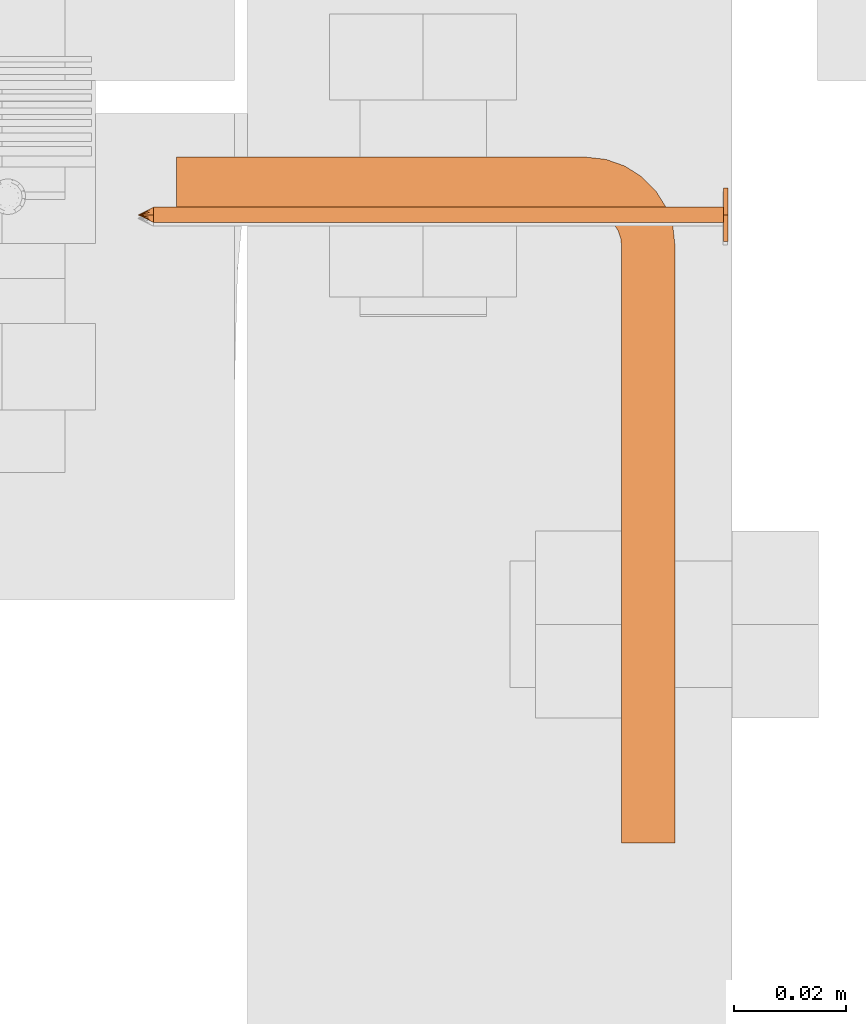
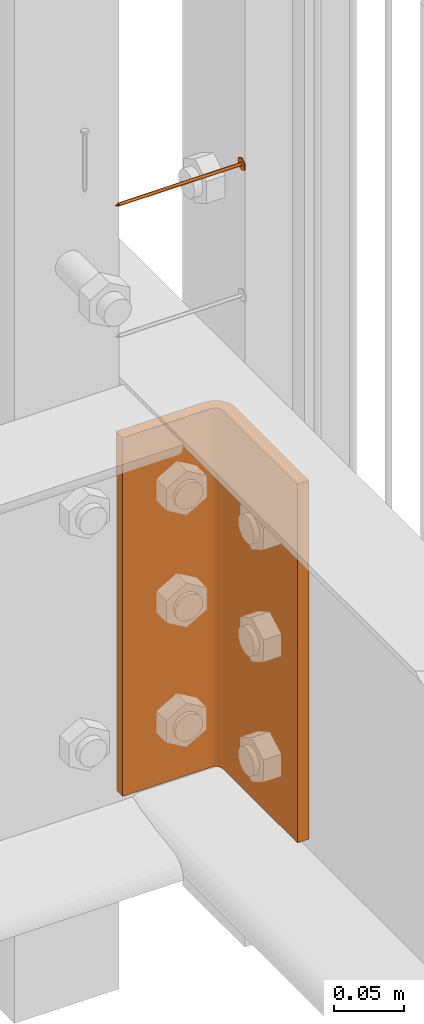
# One storey, part 26 of 44: 2 proxies.
"""IFC4 building model written with IfcOpenShell, lengths in feet."""

from ifc_helpers import new_model, entity, si_unit, converted_unit, derived_unit, direction, frame, frame_2d, origin, place, context, subcontext, project, spatial, polyline, circle_curve, parameter, trimmed, segment, composite_curve, outline, extrude, source, transform, mapped, material, type_object, type_shapes, element, save


model = new_model("IFC4")

# Units and contexts
model_context = context("Model", 3, precision=0.0001, world=origin(), true_north=direction((6.12303176911189e-17, 1.0)))
body_context = subcontext(model_context, "Body", "Model", "MODEL_VIEW")
ifc_project = project(units=[converted_unit("LENGTHUNIT", "FOOT", entity("IfcRatioMeasure", 0.3048), si_unit("LENGTHUNIT", "METRE"), dimensions=[1, 0, 0, 0, 0, 0, 0]), converted_unit("AREAUNIT", "SQUARE FOOT", entity("IfcRatioMeasure", 0.09290304), si_unit("AREAUNIT", "SQUARE_METRE"), dimensions=[2, 0, 0, 0, 0, 0, 0]), converted_unit("VOLUMEUNIT", "CUBIC FOOT", entity("IfcRatioMeasure", 0.028316846592), si_unit("VOLUMEUNIT", "CUBIC_METRE"), dimensions=[3, 0, 0, 0, 0, 0, 0]), converted_unit("PLANEANGLEUNIT", "DEGREE", entity("IfcRatioMeasure", 0.0174532925199433), si_unit("PLANEANGLEUNIT", "RADIAN"), dimensions=[0, 0, 0, 0, 0, 0, 0]), si_unit("MASSUNIT", "GRAM", prefix="KILO"), derived_unit("MASSDENSITYUNIT", [(si_unit("MASSUNIT", "GRAM", prefix="KILO"), 1), (si_unit("LENGTHUNIT", "METRE"), -3)]), derived_unit("MOMENTOFINERTIAUNIT", [(si_unit("LENGTHUNIT", "METRE"), 4)]), si_unit("TIMEUNIT", "SECOND"), si_unit("FREQUENCYUNIT", "HERTZ"), si_unit("THERMODYNAMICTEMPERATUREUNIT", "DEGREE_CELSIUS"), derived_unit("THERMALTRANSMITTANCEUNIT", [(si_unit("MASSUNIT", "GRAM", prefix="KILO"), 1), (si_unit("THERMODYNAMICTEMPERATUREUNIT", "KELVIN"), -1), (si_unit("TIMEUNIT", "SECOND"), -3)]), derived_unit("VOLUMETRICFLOWRATEUNIT", [(si_unit("LENGTHUNIT", "METRE"), 3), (si_unit("TIMEUNIT", "SECOND"), -1)]), si_unit("ELECTRICCURRENTUNIT", "AMPERE"), si_unit("ELECTRICVOLTAGEUNIT", "VOLT"), si_unit("POWERUNIT", "WATT"), si_unit("FORCEUNIT", "NEWTON"), si_unit("ILLUMINANCEUNIT", "LUX"), si_unit("LUMINOUSFLUXUNIT", "LUMEN"), si_unit("LUMINOUSINTENSITYUNIT", "CANDELA"), derived_unit("USERDEFINED", [(si_unit("MASSUNIT", "GRAM", prefix="KILO"), -1), (si_unit("LENGTHUNIT", "METRE"), -2), (si_unit("TIMEUNIT", "SECOND"), 3), (si_unit("LUMINOUSFLUXUNIT", "LUMEN"), 1)]), derived_unit("LINEARVELOCITYUNIT", [(si_unit("LENGTHUNIT", "METRE"), 1), (si_unit("TIMEUNIT", "SECOND"), -1)]), si_unit("PRESSUREUNIT", "PASCAL"), derived_unit("USERDEFINED", [(si_unit("LENGTHUNIT", "METRE"), -2), (si_unit("MASSUNIT", "GRAM", prefix="KILO"), 1), (si_unit("TIMEUNIT", "SECOND"), -2)]), derived_unit("LINEARFORCEUNIT", [(si_unit("MASSUNIT", "GRAM", prefix="KILO"), 1), (si_unit("LENGTHUNIT", "METRE"), 1), (si_unit("TIMEUNIT", "SECOND"), -2), (si_unit("LENGTHUNIT", "METRE"), -1)]), derived_unit("PLANARFORCEUNIT", [(si_unit("MASSUNIT", "GRAM", prefix="KILO"), 1), (si_unit("LENGTHUNIT", "METRE"), 1), (si_unit("TIMEUNIT", "SECOND"), -2), (si_unit("LENGTHUNIT", "METRE"), -2)])], contexts=[model_context])

# Site, building, storey
site_placement = place(None, origin())
site = spatial("IfcSite", under=ifc_project, at=site_placement, CompositionType="ELEMENT")
building_placement = place(site_placement, origin())
building = spatial("IfcBuilding", under=site, at=building_placement, CompositionType="ELEMENT")
storey_placement = place(building_placement, origin())
storey = spatial("IfcBuildingStorey", under=building, at=storey_placement, CompositionType="ELEMENT", Elevation=0.0)

# Proxies
ifc_material_1 = material(Category="Materials")
building_element_proxy_type_1 = type_object("IfcBuildingElementProxyType", PredefinedType="NOTDEFINED", material=ifc_material_1)
cartesian_point_1 = entity("IfcCartesianPoint", [0.0, -0.00455729166677942, -0.333333333333231])
vertex_point_1 = entity("IfcVertexPoint", cartesian_point_1)
cartesian_point_2 = entity("IfcCartesianPoint", [0.0, 0.00455729166667798, -0.333333333333232])
vertex_point_2 = entity("IfcVertexPoint", cartesian_point_2)
cartesian_point_3 = entity("IfcCartesianPoint", [0.0, 0.0, -0.333333333333232])
ifc_direction_1 = entity("IfcDirection", [0.0, 0.0, 1.0])
ifc_direction_2 = entity("IfcDirection", [0.0, 1.0, 0.0])
edge_curve_1 = entity("IfcEdgeCurve", vertex_point_1, vertex_point_2, entity("IfcTrimmedCurve", entity("IfcCircle", entity("IfcAxis2Placement3D", cartesian_point_3, ifc_direction_1, ifc_direction_2), 0.0045572916667287), [cartesian_point_1], [cartesian_point_2], True, "CARTESIAN"), True)
vertex_point_3 = entity("IfcVertexPoint", cartesian_point_3)
ifc_direction_3 = entity("IfcDirection", [0.0, -1.0, 0.0])
edge_curve_2 = entity("IfcEdgeCurve", vertex_point_2, vertex_point_3, entity("IfcTrimmedCurve", entity("IfcLine", cartesian_point_2, entity("IfcVector", ifc_direction_3, 1.0)), [cartesian_point_2], [cartesian_point_3], True, "CARTESIAN"), True)
edge_curve_3 = entity("IfcEdgeCurve", vertex_point_3, vertex_point_1, entity("IfcTrimmedCurve", entity("IfcLine", cartesian_point_3, entity("IfcVector", ifc_direction_3, 1.0)), [cartesian_point_3], [cartesian_point_1], True, "CARTESIAN"), True)
edge_curve_4 = entity("IfcEdgeCurve", vertex_point_2, vertex_point_1, entity("IfcTrimmedCurve", entity("IfcCircle", entity("IfcAxis2Placement3D", cartesian_point_3, ifc_direction_1, ifc_direction_2), 0.0045572916667287), [cartesian_point_2], [cartesian_point_1], True, "CARTESIAN"), True)
cartesian_point_4 = entity("IfcCartesianPoint", [0.0, 0.0, -0.342447916666333])
vertex_point_4 = entity("IfcVertexPoint", cartesian_point_4)
edge_curve_5 = entity("IfcEdgeCurve", vertex_point_4, vertex_point_2, entity("IfcTrimmedCurve", entity("IfcLine", cartesian_point_4, entity("IfcVector", entity("IfcDirection", [0.0, 0.447213595514596, 0.894427190992597]), 1.0)), [cartesian_point_4], [cartesian_point_2], True, "CARTESIAN"), True)
edge_curve_6 = entity("IfcEdgeCurve", vertex_point_1, vertex_point_4, entity("IfcTrimmedCurve", entity("IfcLine", cartesian_point_1, entity("IfcVector", entity("IfcDirection", [0.0, 0.447213595514579, -0.894427190992605]), 1.0)), [cartesian_point_1], [cartesian_point_4], True, "CARTESIAN"), True)
cartesian_point_5 = entity("IfcCartesianPoint", [-0.00455729166669724, 0.0, -0.333333333333231])
cartesian_point_6 = entity("IfcCartesianPoint", [0.0, 0.0, -0.338202184590857])
ifc_direction_4 = entity("IfcDirection", [0.0, 0.0, -1.0])
cartesian_point_7 = entity("IfcCartesianPoint", [-0.0156249999999625, 0.00902109795594613, 0.00260416666704037])
vertex_point_5 = entity("IfcVertexPoint", cartesian_point_7)
cartesian_point_8 = entity("IfcCartesianPoint", [-0.0156249999999625, -0.0090210979562493, 0.00260416666704046])
vertex_point_6 = entity("IfcVertexPoint", cartesian_point_8)
ifc_direction_5 = entity("IfcDirection", [0.0, -1.0, 0.0])
edge_curve_7 = entity("IfcEdgeCurve", vertex_point_5, vertex_point_6, entity("IfcTrimmedCurve", entity("IfcLine", cartesian_point_7, entity("IfcVector", ifc_direction_5, 1.0)), [cartesian_point_7], [cartesian_point_8], True, "CARTESIAN"), True)
cartesian_point_9 = entity("IfcCartesianPoint", [0.0, -0.0180421959123274, 0.0026041666670405])
vertex_point_7 = entity("IfcVertexPoint", cartesian_point_9)
edge_curve_8 = entity("IfcEdgeCurve", vertex_point_6, vertex_point_7, entity("IfcTrimmedCurve", entity("IfcLine", cartesian_point_8, entity("IfcVector", entity("IfcDirection", [0.866025403784438, -0.500000000000001, 0.0]), 1.0)), [cartesian_point_8], [cartesian_point_9], True, "CARTESIAN"), True)
cartesian_point_10 = entity("IfcCartesianPoint", [0.0156250000000786, -0.00902109795620598, 0.00260416666704046])
vertex_point_8 = entity("IfcVertexPoint", cartesian_point_10)
edge_curve_9 = entity("IfcEdgeCurve", vertex_point_7, vertex_point_8, entity("IfcTrimmedCurve", entity("IfcLine", cartesian_point_9, entity("IfcVector", entity("IfcDirection", [0.86602540378444, 0.499999999999998, 0.0]), 1.0)), [cartesian_point_9], [cartesian_point_10], True, "CARTESIAN"), True)
cartesian_point_11 = entity("IfcCartesianPoint", [0.0156250000000786, 0.00902109795590273, 0.00260416666704037])
vertex_point_9 = entity("IfcVertexPoint", cartesian_point_11)
ifc_direction_6 = entity("IfcDirection", [0.0, 1.0, 0.0])
edge_curve_10 = entity("IfcEdgeCurve", vertex_point_8, vertex_point_9, entity("IfcTrimmedCurve", entity("IfcLine", cartesian_point_10, entity("IfcVector", ifc_direction_6, 1.0)), [cartesian_point_10], [cartesian_point_11], True, "CARTESIAN"), True)
cartesian_point_12 = entity("IfcCartesianPoint", [0.0, 0.0180421959120243, 0.00260416666704032])
vertex_point_10 = entity("IfcVertexPoint", cartesian_point_12)
edge_curve_11 = entity("IfcEdgeCurve", vertex_point_9, vertex_point_10, entity("IfcTrimmedCurve", entity("IfcLine", cartesian_point_11, entity("IfcVector", entity("IfcDirection", [-0.866025403784437, 0.500000000000003, 0.0]), 1.0)), [cartesian_point_11], [cartesian_point_12], True, "CARTESIAN"), True)
edge_curve_12 = entity("IfcEdgeCurve", vertex_point_10, vertex_point_5, entity("IfcTrimmedCurve", entity("IfcLine", cartesian_point_12, entity("IfcVector", entity("IfcDirection", [-0.866025403784438, -0.500000000000001, 0.0]), 1.0)), [cartesian_point_12], [cartesian_point_7], True, "CARTESIAN"), True)
ifc_direction_7 = entity("IfcDirection", [0.0, 0.0, 1.0])
cartesian_point_13 = entity("IfcCartesianPoint", [-0.0156249999999625, 0.00902109795594612, 0.0])
vertex_point_11 = entity("IfcVertexPoint", cartesian_point_13)
cartesian_point_14 = entity("IfcCartesianPoint", [0.0, 0.0180421959120242, 0.0])
vertex_point_12 = entity("IfcVertexPoint", cartesian_point_14)
edge_curve_13 = entity("IfcEdgeCurve", vertex_point_11, vertex_point_12, entity("IfcTrimmedCurve", entity("IfcLine", cartesian_point_13, entity("IfcVector", entity("IfcDirection", [0.866025403784438, 0.500000000000001, 0.0]), 1.0)), [cartesian_point_13], [cartesian_point_14], True, "CARTESIAN"), True)
cartesian_point_15 = entity("IfcCartesianPoint", [0.0156250000000786, 0.00902109795590272, 0.0])
vertex_point_13 = entity("IfcVertexPoint", cartesian_point_15)
edge_curve_14 = entity("IfcEdgeCurve", vertex_point_12, vertex_point_13, entity("IfcTrimmedCurve", entity("IfcLine", cartesian_point_14, entity("IfcVector", entity("IfcDirection", [0.866025403784437, -0.500000000000003, 0.0]), 1.0)), [cartesian_point_14], [cartesian_point_15], True, "CARTESIAN"), True)
cartesian_point_16 = entity("IfcCartesianPoint", [0.0156250000000786, -0.00902109795620599, 0.0])
vertex_point_14 = entity("IfcVertexPoint", cartesian_point_16)
edge_curve_15 = entity("IfcEdgeCurve", vertex_point_13, vertex_point_14, entity("IfcTrimmedCurve", entity("IfcLine", cartesian_point_15, entity("IfcVector", ifc_direction_5, 1.0)), [cartesian_point_15], [cartesian_point_16], True, "CARTESIAN"), True)
cartesian_point_17 = entity("IfcCartesianPoint", [0.0, -0.0180421959123274, 0.0])
vertex_point_15 = entity("IfcVertexPoint", cartesian_point_17)
edge_curve_16 = entity("IfcEdgeCurve", vertex_point_14, vertex_point_15, entity("IfcTrimmedCurve", entity("IfcLine", cartesian_point_16, entity("IfcVector", entity("IfcDirection", [-0.86602540378444, -0.499999999999998, 0.0]), 1.0)), [cartesian_point_16], [cartesian_point_17], True, "CARTESIAN"), True)
cartesian_point_18 = entity("IfcCartesianPoint", [-0.0156249999999625, -0.00902109795624931, 0.0])
vertex_point_16 = entity("IfcVertexPoint", cartesian_point_18)
edge_curve_17 = entity("IfcEdgeCurve", vertex_point_15, vertex_point_16, entity("IfcTrimmedCurve", entity("IfcLine", cartesian_point_17, entity("IfcVector", entity("IfcDirection", [-0.866025403784438, 0.500000000000001, 0.0]), 1.0)), [cartesian_point_17], [cartesian_point_18], True, "CARTESIAN"), True)
edge_curve_18 = entity("IfcEdgeCurve", vertex_point_16, vertex_point_11, entity("IfcTrimmedCurve", entity("IfcLine", cartesian_point_18, entity("IfcVector", ifc_direction_6, 1.0)), [cartesian_point_18], [cartesian_point_13], True, "CARTESIAN"), True)
ifc_direction_8 = entity("IfcDirection", [0.0, 0.0, -1.0])
edge_curve_19 = entity("IfcEdgeCurve", vertex_point_5, vertex_point_11, entity("IfcTrimmedCurve", entity("IfcLine", cartesian_point_7, entity("IfcVector", ifc_direction_8, 1.0)), [cartesian_point_7], [cartesian_point_13], True, "CARTESIAN"), True)
edge_curve_20 = entity("IfcEdgeCurve", vertex_point_16, vertex_point_6, entity("IfcTrimmedCurve", entity("IfcLine", cartesian_point_8, entity("IfcVector", ifc_direction_7, 1.0)), [cartesian_point_18], [cartesian_point_8], True, "CARTESIAN"), True)
edge_curve_21 = entity("IfcEdgeCurve", vertex_point_15, vertex_point_7, entity("IfcTrimmedCurve", entity("IfcLine", cartesian_point_9, entity("IfcVector", ifc_direction_7, 1.0)), [cartesian_point_17], [cartesian_point_9], True, "CARTESIAN"), True)
edge_curve_22 = entity("IfcEdgeCurve", vertex_point_14, vertex_point_8, entity("IfcTrimmedCurve", entity("IfcLine", cartesian_point_10, entity("IfcVector", ifc_direction_7, 1.0)), [cartesian_point_16], [cartesian_point_10], True, "CARTESIAN"), True)
edge_curve_23 = entity("IfcEdgeCurve", vertex_point_13, vertex_point_9, entity("IfcTrimmedCurve", entity("IfcLine", cartesian_point_11, entity("IfcVector", ifc_direction_7, 1.0)), [cartesian_point_15], [cartesian_point_11], True, "CARTESIAN"), True)
edge_curve_24 = entity("IfcEdgeCurve", vertex_point_12, vertex_point_10, entity("IfcTrimmedCurve", entity("IfcLine", cartesian_point_12, entity("IfcVector", ifc_direction_7, 1.0)), [cartesian_point_14], [cartesian_point_12], True, "CARTESIAN"), True)
cartesian_point_19 = entity("IfcCartesianPoint", [0.0, -0.00455729166682102, 0.0])
vertex_point_17 = entity("IfcVertexPoint", cartesian_point_19)
cartesian_point_20 = entity("IfcCartesianPoint", [0.0, 0.00455729166651231, 0.0])
vertex_point_18 = entity("IfcVertexPoint", cartesian_point_20)
cartesian_point_21 = entity("IfcCartesianPoint", [0.0, 0.0, 0.0])
ifc_direction_9 = entity("IfcDirection", [0.0, 0.0, 1.0])
ifc_direction_10 = entity("IfcDirection", [0.0, 1.0, 0.0])
edge_curve_25 = entity("IfcEdgeCurve", vertex_point_17, vertex_point_18, entity("IfcTrimmedCurve", entity("IfcCircle", entity("IfcAxis2Placement3D", cartesian_point_21, ifc_direction_9, ifc_direction_10), 0.00455729166666667), [cartesian_point_19], [cartesian_point_20], True, "CARTESIAN"), True)
edge_curve_26 = entity("IfcEdgeCurve", vertex_point_18, vertex_point_17, entity("IfcTrimmedCurve", entity("IfcCircle", entity("IfcAxis2Placement3D", cartesian_point_21, ifc_direction_9, ifc_direction_10), 0.00455729166666667), [cartesian_point_20], [cartesian_point_19], True, "CARTESIAN"), True)
cartesian_point_22 = entity("IfcCartesianPoint", [0.0, -0.00455729166682389, -0.333333333333339])
vertex_point_19 = entity("IfcVertexPoint", cartesian_point_22)
cartesian_point_23 = entity("IfcCartesianPoint", [0.0, 0.00455729166650944, -0.333333333333339])
vertex_point_20 = entity("IfcVertexPoint", cartesian_point_23)
cartesian_point_24 = entity("IfcCartesianPoint", [0.0, 0.0, -0.333333333333339])
ifc_direction_11 = entity("IfcDirection", [0.0, 0.0, -1.0])
edge_curve_27 = entity("IfcEdgeCurve", vertex_point_19, vertex_point_20, entity("IfcTrimmedCurve", entity("IfcCircle", entity("IfcAxis2Placement3D", cartesian_point_24, ifc_direction_11, ifc_direction_10), 0.00455729166666667), [cartesian_point_22], [cartesian_point_23], True, "CARTESIAN"), True)
edge_curve_28 = entity("IfcEdgeCurve", vertex_point_20, vertex_point_19, entity("IfcTrimmedCurve", entity("IfcCircle", entity("IfcAxis2Placement3D", cartesian_point_24, ifc_direction_11, ifc_direction_10), 0.00455729166666667), [cartesian_point_23], [cartesian_point_22], True, "CARTESIAN"), True)
edge_curve_29 = entity("IfcEdgeCurve", vertex_point_17, vertex_point_19, entity("IfcTrimmedCurve", entity("IfcLine", cartesian_point_19, entity("IfcVector", ifc_direction_11, 1.0)), [cartesian_point_19], [cartesian_point_22], True, "CARTESIAN"), True)
edge_curve_30 = entity("IfcEdgeCurve", vertex_point_20, vertex_point_18, entity("IfcTrimmedCurve", entity("IfcLine", cartesian_point_20, entity("IfcVector", ifc_direction_9, 1.0)), [cartesian_point_23], [cartesian_point_20], True, "CARTESIAN"), True)
shared_shape_1 = source(origin(), body_context, "Body", "AdvancedBrep", [
    entity("IfcAdvancedBrep", entity("IfcClosedShell", [entity("IfcAdvancedFace", [entity("IfcFaceOuterBound", entity("IfcEdgeLoop", [entity("IfcOrientedEdge", None, None, edge_curve_1, True), entity("IfcOrientedEdge", None, None, edge_curve_2, True), entity("IfcOrientedEdge", None, None, edge_curve_3, True)]), True)], entity("IfcPlane", entity("IfcAxis2Placement3D", cartesian_point_3, ifc_direction_1, ifc_direction_2)), True), entity("IfcAdvancedFace", [entity("IfcFaceOuterBound", entity("IfcEdgeLoop", [entity("IfcOrientedEdge", None, None, edge_curve_4, True), entity("IfcOrientedEdge", None, None, edge_curve_3, False), entity("IfcOrientedEdge", None, None, edge_curve_2, False)]), True)], entity("IfcPlane", entity("IfcAxis2Placement3D", cartesian_point_3, ifc_direction_1, ifc_direction_2)), True), entity("IfcAdvancedFace", [entity("IfcFaceOuterBound", entity("IfcEdgeLoop", [entity("IfcOrientedEdge", None, None, edge_curve_5, True), entity("IfcOrientedEdge", None, None, edge_curve_1, False), entity("IfcOrientedEdge", None, None, edge_curve_6, True)]), True)], entity("IfcSurfaceOfRevolution", entity("IfcArbitraryOpenProfileDef", "CURVE", None, entity("IfcTrimmedCurve", entity("IfcLine", cartesian_point_4, entity("IfcVector", entity("IfcDirection", [0.447213595514577, 0.0, -0.894427190992606]), 1.0)), [cartesian_point_5], [cartesian_point_4], True, "CARTESIAN")), None, entity("IfcAxis1Placement", cartesian_point_6, ifc_direction_4)), True), entity("IfcAdvancedFace", [entity("IfcFaceOuterBound", entity("IfcEdgeLoop", [entity("IfcOrientedEdge", None, None, edge_curve_6, False), entity("IfcOrientedEdge", None, None, edge_curve_4, False), entity("IfcOrientedEdge", None, None, edge_curve_5, False)]), True)], entity("IfcSurfaceOfRevolution", entity("IfcArbitraryOpenProfileDef", "CURVE", None, entity("IfcTrimmedCurve", entity("IfcLine", cartesian_point_4, entity("IfcVector", entity("IfcDirection", [0.447213595514577, 0.0, -0.894427190992606]), 1.0)), [cartesian_point_5], [cartesian_point_4], True, "CARTESIAN")), None, entity("IfcAxis1Placement", cartesian_point_6, ifc_direction_4)), True)])),
    entity("IfcAdvancedBrep", entity("IfcClosedShell", [entity("IfcAdvancedFace", [entity("IfcFaceOuterBound", entity("IfcEdgeLoop", [entity("IfcOrientedEdge", None, None, edge_curve_7, True), entity("IfcOrientedEdge", None, None, edge_curve_8, True), entity("IfcOrientedEdge", None, None, edge_curve_9, True), entity("IfcOrientedEdge", None, None, edge_curve_10, True), entity("IfcOrientedEdge", None, None, edge_curve_11, True), entity("IfcOrientedEdge", None, None, edge_curve_12, True)]), True)], entity("IfcPlane", entity("IfcAxis2Placement3D", cartesian_point_7, ifc_direction_7, ifc_direction_5)), True), entity("IfcAdvancedFace", [entity("IfcFaceOuterBound", entity("IfcEdgeLoop", [entity("IfcOrientedEdge", None, None, edge_curve_13, True), entity("IfcOrientedEdge", None, None, edge_curve_14, True), entity("IfcOrientedEdge", None, None, edge_curve_15, True), entity("IfcOrientedEdge", None, None, edge_curve_16, True), entity("IfcOrientedEdge", None, None, edge_curve_17, True), entity("IfcOrientedEdge", None, None, edge_curve_18, True)]), True)], entity("IfcPlane", entity("IfcAxis2Placement3D", cartesian_point_13, ifc_direction_8, ifc_direction_6)), True), entity("IfcAdvancedFace", [entity("IfcFaceOuterBound", entity("IfcEdgeLoop", [entity("IfcOrientedEdge", None, None, edge_curve_7, False), entity("IfcOrientedEdge", None, None, edge_curve_19, True), entity("IfcOrientedEdge", None, None, edge_curve_18, False), entity("IfcOrientedEdge", None, None, edge_curve_20, True)]), True)], entity("IfcPlane", entity("IfcAxis2Placement3D", cartesian_point_7, entity("IfcDirection", [-1.0, 0.0, 0.0]), ifc_direction_8)), True), entity("IfcAdvancedFace", [entity("IfcFaceOuterBound", entity("IfcEdgeLoop", [entity("IfcOrientedEdge", None, None, edge_curve_8, False), entity("IfcOrientedEdge", None, None, edge_curve_20, False), entity("IfcOrientedEdge", None, None, edge_curve_17, False), entity("IfcOrientedEdge", None, None, edge_curve_21, True)]), True)], entity("IfcPlane", entity("IfcAxis2Placement3D", cartesian_point_8, entity("IfcDirection", [-0.500000000000001, -0.866025403784438, 0.0]), ifc_direction_8)), True), entity("IfcAdvancedFace", [entity("IfcFaceOuterBound", entity("IfcEdgeLoop", [entity("IfcOrientedEdge", None, None, edge_curve_9, False), entity("IfcOrientedEdge", None, None, edge_curve_21, False), entity("IfcOrientedEdge", None, None, edge_curve_16, False), entity("IfcOrientedEdge", None, None, edge_curve_22, True)]), True)], entity("IfcPlane", entity("IfcAxis2Placement3D", cartesian_point_9, entity("IfcDirection", [0.499999999999998, -0.86602540378444, 0.0]), ifc_direction_8)), True), entity("IfcAdvancedFace", [entity("IfcFaceOuterBound", entity("IfcEdgeLoop", [entity("IfcOrientedEdge", None, None, edge_curve_10, False), entity("IfcOrientedEdge", None, None, edge_curve_22, False), entity("IfcOrientedEdge", None, None, edge_curve_15, False), entity("IfcOrientedEdge", None, None, edge_curve_23, True)]), True)], entity("IfcPlane", entity("IfcAxis2Placement3D", cartesian_point_10, entity("IfcDirection", [1.0, 0.0, 0.0]), ifc_direction_8)), True), entity("IfcAdvancedFace", [entity("IfcFaceOuterBound", entity("IfcEdgeLoop", [entity("IfcOrientedEdge", None, None, edge_curve_11, False), entity("IfcOrientedEdge", None, None, edge_curve_23, False), entity("IfcOrientedEdge", None, None, edge_curve_14, False), entity("IfcOrientedEdge", None, None, edge_curve_24, True)]), True)], entity("IfcPlane", entity("IfcAxis2Placement3D", cartesian_point_11, entity("IfcDirection", [0.500000000000003, 0.866025403784437, 0.0]), ifc_direction_8)), True), entity("IfcAdvancedFace", [entity("IfcFaceOuterBound", entity("IfcEdgeLoop", [entity("IfcOrientedEdge", None, None, edge_curve_12, False), entity("IfcOrientedEdge", None, None, edge_curve_24, False), entity("IfcOrientedEdge", None, None, edge_curve_13, False), entity("IfcOrientedEdge", None, None, edge_curve_19, False)]), True)], entity("IfcPlane", entity("IfcAxis2Placement3D", cartesian_point_12, entity("IfcDirection", [-0.500000000000001, 0.866025403784438, 0.0]), ifc_direction_8)), True)])),
    entity("IfcAdvancedBrep", entity("IfcClosedShell", [entity("IfcAdvancedFace", [entity("IfcFaceOuterBound", entity("IfcEdgeLoop", [entity("IfcOrientedEdge", None, None, edge_curve_25, True), entity("IfcOrientedEdge", None, None, edge_curve_26, True)]), True)], entity("IfcPlane", entity("IfcAxis2Placement3D", cartesian_point_20, ifc_direction_9, entity("IfcDirection", [-1.0, 0.0, 0.0]))), True), entity("IfcAdvancedFace", [entity("IfcFaceOuterBound", entity("IfcEdgeLoop", [entity("IfcOrientedEdge", None, None, edge_curve_27, True), entity("IfcOrientedEdge", None, None, edge_curve_28, True)]), True)], entity("IfcPlane", entity("IfcAxis2Placement3D", cartesian_point_23, ifc_direction_11, entity("IfcDirection", [1.0, 0.0, 0.0]))), True), entity("IfcAdvancedFace", [entity("IfcFaceOuterBound", entity("IfcEdgeLoop", [entity("IfcOrientedEdge", None, None, edge_curve_25, False), entity("IfcOrientedEdge", None, None, edge_curve_29, True), entity("IfcOrientedEdge", None, None, edge_curve_28, False), entity("IfcOrientedEdge", None, None, edge_curve_30, True)]), True)], entity("IfcCylindricalSurface", entity("IfcAxis2Placement3D", cartesian_point_24, ifc_direction_9, ifc_direction_10), 0.00455729166666667), True), entity("IfcAdvancedFace", [entity("IfcFaceOuterBound", entity("IfcEdgeLoop", [entity("IfcOrientedEdge", None, None, edge_curve_26, False), entity("IfcOrientedEdge", None, None, edge_curve_30, False), entity("IfcOrientedEdge", None, None, edge_curve_27, False), entity("IfcOrientedEdge", None, None, edge_curve_29, False)]), True)], entity("IfcCylindricalSurface", entity("IfcAxis2Placement3D", cartesian_point_24, ifc_direction_9, ifc_direction_10), 0.00455729166666667), True)])),
])
type_shapes(building_element_proxy_type_1, [shared_shape_1])
proxy_1_placement = place(storey_placement, frame((1494.28730072243, 4.6792698150424, 10.4899253669743), z_axis=(1.0, 0.0, 0.0), x_axis=(0.0, 1.0, 0.0)))
element("IfcBuildingElementProxy", 1, at=proxy_1_placement, inside=storey, type_object=building_element_proxy_type_1, material=ifc_material_1, PredefinedType="NOTDEFINED", context=body_context, shape_type="MappedRepresentation", body=[
    mapped(shared_shape_1, transform((0.0, 0.0, 0.0), scale=1.0)),
])
ifc_material_2 = material(Category="Materials")
building_element_proxy_type_2 = type_object("IfcBuildingElementProxyType", PredefinedType="NOTDEFINED", material=ifc_material_2)
shared_shape_2 = source(origin(), body_context, "Body", "SweptSolid", [
    extrude(outline(composite_curve([segment(polyline([(-0.0416666666669703, -0.121093750000012), (0.197916666666515, -0.121093750000012)]), True, "CONTINUOUS"), segment(polyline([(0.197916666666515, -0.121093750000012), (0.197916666666515, -0.0898437500000123)]), True, "CONTINUOUS"), segment(polyline([(0.197916666666515, -0.0898437500000123), (-0.0416666666669702, -0.0898437500000123)]), True, "CONTINUOUS"), segment(trimmed(circle_curve(frame_2d((-0.0416666666669701, -0.0690104166666792), x_axis=(0.0, 1.0)), 0.0208333333333333), [parameter(89.9999999999999)], [parameter(180.0)], True, "PARAMETER"), False, "CONTINUOUS"), segment(polyline([(-0.0625000000002276, -0.0690104166666792), (-0.0625000000002263, 0.279947916666703)]), True, "CONTINUOUS"), segment(polyline([(-0.0625000000002263, 0.279947916666703), (-0.0937500000002263, 0.279947916666703)]), True, "CONTINUOUS"), segment(polyline([(-0.0937500000002263, 0.279947916666703), (-0.0937500000002276, -0.0690104166666791)]), True, "CONTINUOUS"), segment(trimmed(circle_curve(frame_2d((-0.0416666666669701, -0.0690104166666792), x_axis=(0.0, 1.0)), 0.0520833333333333), [parameter(89.9999999999999)], [parameter(180.0)], True, "PARAMETER"), True, "CONTINUOUS")], self_intersect=False)), frame((0.197916666666742, 0.279947916666702, 0.0), z_axis=(0.0, 0.0, 1.0), x_axis=(-1.0, 0.0, 0.0)), (0.0, 0.0, 1.0), 1.02819111030574),
])
type_shapes(building_element_proxy_type_2, [shared_shape_2])
proxy_2_placement = place(storey_placement, frame((1493.96728937919, 4.31201087109968, 8.78669500610661)))
element("IfcBuildingElementProxy", 2, at=proxy_2_placement, inside=storey, type_object=building_element_proxy_type_2, material=ifc_material_2, PredefinedType="NOTDEFINED", context=body_context, shape_type="MappedRepresentation", body=[
    mapped(shared_shape_2, transform((0.0, 0.0, 0.0), scale=1.0)),
])

save(model, "model.ifc")
